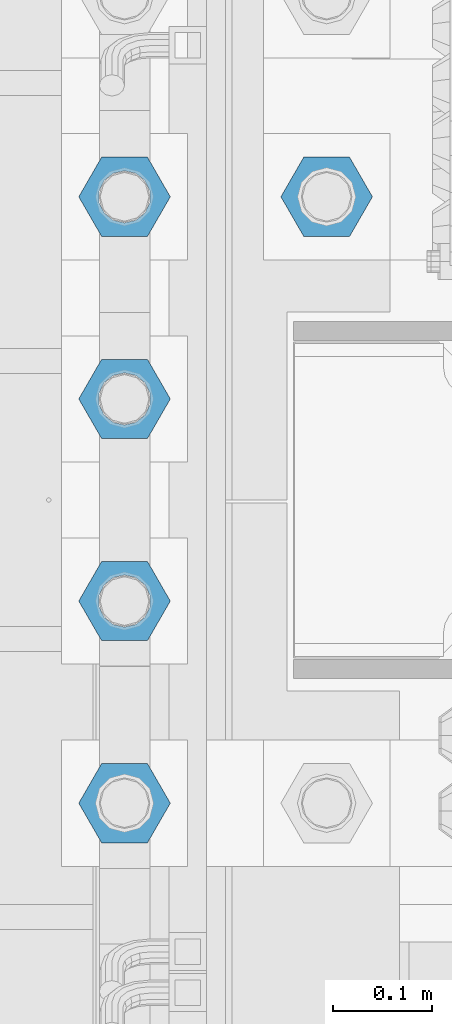
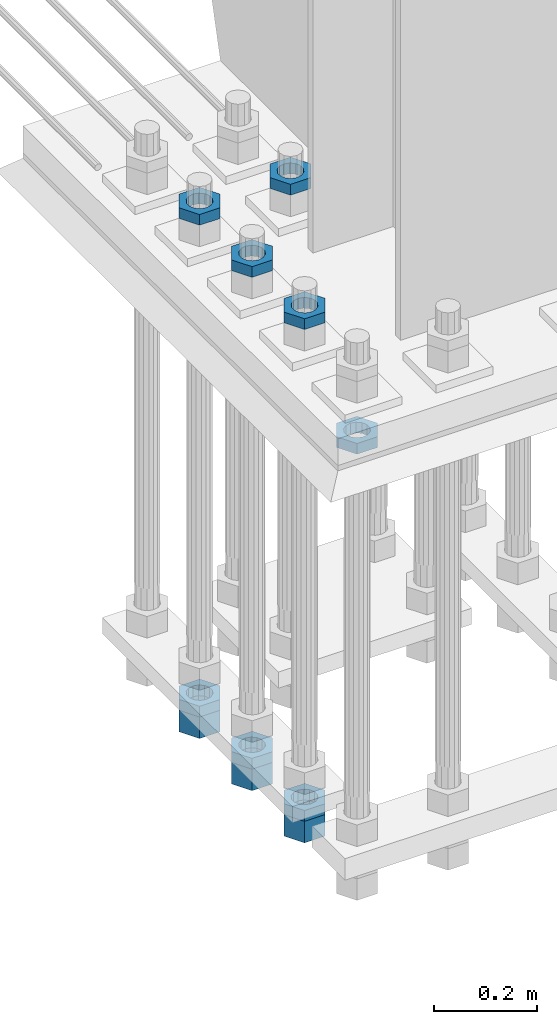
# One storey, part 2091 of 3843: 11 beams, 1 element without a shape of its own.
"""IFC2X3 building model written with IfcOpenShell, lengths in millimetres."""

from ifc_helpers import new_model, si_unit, frame, origin_with_axes, place, context, subcontext, project, spatial, faceted_brep, material, type_object, element, aggregate, save


model = new_model("IFC2X3")

# Units and contexts
model_context = context("Model", 3, precision=1e-05, world=origin_with_axes())
body_context = subcontext(model_context, "Body", "Model", "MODEL_VIEW")
ifc_project = project(units=[si_unit("LENGTHUNIT", "METRE", prefix="MILLI"), si_unit("AREAUNIT", "SQUARE_METRE"), si_unit("VOLUMEUNIT", "CUBIC_METRE"), si_unit("MASSUNIT", "GRAM", prefix="KILO"), si_unit("TIMEUNIT", "SECOND"), si_unit("PLANEANGLEUNIT", "RADIAN"), si_unit("SOLIDANGLEUNIT", "STERADIAN"), si_unit("THERMODYNAMICTEMPERATUREUNIT", "DEGREE_CELSIUS"), si_unit("LUMINOUSINTENSITYUNIT", "LUMEN")], contexts=[model_context])

# Site, building, storey
site_placement = place(None, origin_with_axes())
site = spatial("IfcSite", under=ifc_project, at=site_placement, CompositionType="ELEMENT")
building_placement = place(site_placement, origin_with_axes())
building = spatial("IfcBuilding", under=site, at=building_placement, Name="Undefined", CompositionType="ELEMENT")
storey_placement = place(building_placement, origin_with_axes())
storey = spatial("IfcBuildingStorey", under=building, at=storey_placement, Name="Undefined", CompositionType="ELEMENT", Elevation=0.0)

# Assembly, beams
assembly_placement = place(storey_placement, origin_with_axes())
assembly = element("IfcElementAssembly", 1, at=assembly_placement, inside=storey, Name="TEMPLATE", AssemblyPlace="NOTDEFINED", PredefinedType="RIGID_FRAME")
ifc_material = material(Name="STEEL/A572-50")
beam_type_1 = type_object("IfcBeamType", Name="2_HALF_NUT", PredefinedType="NOTDEFINED")
beam_1_placement = place(assembly_placement, frame((55575.2, 20002.5, 29603.7), z_axis=(0.0, -1.0, 0.0), x_axis=(0.0, 0.0, -1.0)))
beam_1 = element("IfcBeam", 2, at=beam_1_placement, type_object=beam_type_1, material=ifc_material, Name="NUT", ObjectType="2_HALF_NUT", context=body_context, shape_type="Brep", body=[
    faceted_brep([(0.0, -46.0369987487793, 0.0), (0.0, -23.0184993743896, -39.869213104248), (25.4000000000015, -23.0184993743896, -39.869213104248), (25.4000000000015, -46.0369987487793, 0.0), (0.0, 23.0184993743896, -39.869213104248), (25.4000000000015, 23.0184993743896, -39.869213104248), (0.0, 46.0369987487793, 0.0), (25.4000000000015, 46.0369987487793, 0.0), (0.0, 23.0184993743896, 39.869213104248), (25.4000000000015, 23.0184993743896, 39.869213104248), (0.0, -23.0184993743896, 39.869213104248), (25.4000000000015, -23.0184993743896, 39.869213104248), (0.0, 0.0, 26.1940002441406), (0.0, 11.3650617044477, 23.5999013092805), (25.4000000000015, 11.3650617044477, 23.5999013092805), (25.4000000000015, 0.0, 26.1940002441406), (0.0, 20.4791109456419, 16.3316083006721), (25.4000000000015, 20.4791109456419, 16.3316083006721), (0.0, 25.5370200498292, 5.82867859874386), (25.4000000000015, 25.5370200498292, 5.82867859874386), (0.0, 25.5370200498292, -5.82867859874386), (25.4000000000015, 25.5370200498292, -5.82867859874386), (0.0, 20.4791109456419, -16.3316083006721), (25.4000000000015, 20.4791109456419, -16.3316083006721), (0.0, 11.3650617044477, -23.5999013092805), (25.4000000000015, 11.3650617044477, -23.5999013092805), (0.0, 0.0, -26.1940002441406), (25.4000000000015, 0.0, -26.1940002441406), (0.0, -11.3650617044477, -23.5999013092805), (25.4000000000015, -11.3650617044477, -23.5999013092805), (0.0, -20.4791109456419, -16.3316083006721), (25.4000000000015, -20.4791109456419, -16.3316083006721), (0.0, -25.5370200498292, -5.82867859874386), (25.4000000000015, -25.5370200498292, -5.82867859874386), (0.0, -25.5370200498292, 5.82867859874386), (25.4000000000015, -25.5370200498292, 5.82867859874386), (0.0, -20.4791109456419, 16.3316083006721), (25.4000000000015, -20.4791109456419, 16.3316083006721), (0.0, -11.3650617044477, 23.5999013092805), (25.4000000000015, -11.3650617044477, 23.5999013092805)], [[[0, 1, 2, 3]], [[1, 4, 5, 2]], [[4, 6, 7, 5]], [[6, 8, 9, 7]], [[8, 10, 11, 9]], [[10, 0, 3, 11]], [[12, 13, 14, 15]], [[13, 16, 17, 14]], [[16, 18, 19, 17]], [[18, 20, 21, 19]], [[20, 22, 23, 21]], [[22, 24, 25, 23]], [[24, 26, 27, 25]], [[26, 28, 29, 27]], [[28, 30, 31, 29]], [[30, 32, 33, 31]], [[32, 34, 35, 33]], [[34, 36, 37, 35]], [[36, 38, 39, 37]], [[38, 12, 15, 39]], [[5, 7, 9, 11, 3, 2], [17, 19, 21, 23, 25, 27, 29, 31, 33, 35, 37, 39, 15, 14]], [[10, 8, 6, 4, 1, 0], [38, 36, 34, 32, 30, 28, 26, 24, 22, 20, 18, 16, 13, 12]]]),
])
beam_2_placement = place(assembly_placement, frame((55575.2, 20205.7, 29775.15), z_axis=(0.0, -1.0, 0.0), x_axis=(0.0, 0.0, -1.0)))
beam_2 = element("IfcBeam", 3, at=beam_2_placement, type_object=beam_type_1, material=ifc_material, Name="NUT", ObjectType="2_HALF_NUT", context=body_context, shape_type="Brep", body=[
    faceted_brep([(0.0, -46.0369987487793, 0.0), (0.0, -23.0184993743896, -39.869213104248), (25.4000000000015, -23.0184993743896, -39.869213104248), (25.4000000000015, -46.0369987487793, 0.0), (0.0, 23.0184993743896, -39.869213104248), (25.4000000000015, 23.0184993743896, -39.869213104248), (0.0, 46.0369987487793, 0.0), (25.4000000000015, 46.0369987487793, 0.0), (0.0, 23.0184993743896, 39.869213104248), (25.4000000000015, 23.0184993743896, 39.869213104248), (0.0, -23.0184993743896, 39.869213104248), (25.4000000000015, -23.0184993743896, 39.869213104248), (0.0, 0.0, 26.1940002441406), (0.0, 11.3650617044477, 23.5999013092805), (25.4000000000015, 11.3650617044477, 23.5999013092805), (25.4000000000015, 0.0, 26.1940002441406), (0.0, 20.4791109456419, 16.3316083006721), (25.4000000000015, 20.4791109456419, 16.3316083006721), (0.0, 25.5370200498292, 5.82867859874386), (25.4000000000015, 25.5370200498292, 5.82867859874386), (0.0, 25.5370200498292, -5.82867859874386), (25.4000000000015, 25.5370200498292, -5.82867859874386), (0.0, 20.4791109456419, -16.3316083006721), (25.4000000000015, 20.4791109456419, -16.3316083006721), (0.0, 11.3650617044477, -23.5999013092805), (25.4000000000015, 11.3650617044477, -23.5999013092805), (0.0, 0.0, -26.1940002441406), (25.4000000000015, 0.0, -26.1940002441406), (0.0, -11.3650617044477, -23.5999013092805), (25.4000000000015, -11.3650617044477, -23.5999013092805), (0.0, -20.4791109456419, -16.3316083006721), (25.4000000000015, -20.4791109456419, -16.3316083006721), (0.0, -25.5370200498292, -5.82867859874386), (25.4000000000015, -25.5370200498292, -5.82867859874386), (0.0, -25.5370200498292, 5.82867859874386), (25.4000000000015, -25.5370200498292, 5.82867859874386), (0.0, -20.4791109456419, 16.3316083006721), (25.4000000000015, -20.4791109456419, 16.3316083006721), (0.0, -11.3650617044477, 23.5999013092805), (25.4000000000015, -11.3650617044477, 23.5999013092805)], [[[0, 1, 2, 3]], [[1, 4, 5, 2]], [[4, 6, 7, 5]], [[6, 8, 9, 7]], [[8, 10, 11, 9]], [[10, 0, 3, 11]], [[12, 13, 14, 15]], [[13, 16, 17, 14]], [[16, 18, 19, 17]], [[18, 20, 21, 19]], [[20, 22, 23, 21]], [[22, 24, 25, 23]], [[24, 26, 27, 25]], [[26, 28, 29, 27]], [[28, 30, 31, 29]], [[30, 32, 33, 31]], [[32, 34, 35, 33]], [[34, 36, 37, 35]], [[36, 38, 39, 37]], [[38, 12, 15, 39]], [[5, 7, 9, 11, 3, 2], [17, 19, 21, 23, 25, 27, 29, 31, 33, 35, 37, 39, 15, 14]], [[10, 8, 6, 4, 1, 0], [38, 36, 34, 32, 30, 28, 26, 24, 22, 20, 18, 16, 13, 12]]]),
])
beam_3_placement = place(assembly_placement, frame((55575.2, 20205.7, 28613.0999969482), z_axis=(0.0, -1.0, 0.0), x_axis=(0.0, 0.0, -1.0)))
beam_3 = element("IfcBeam", 4, at=beam_3_placement, type_object=beam_type_1, material=ifc_material, Name="NUT", ObjectType="2_HALF_NUT", context=body_context, shape_type="Brep", body=[
    faceted_brep([(0.0, -46.0369987487793, 0.0), (0.0, -23.0184993743896, -39.869213104248), (25.4000000000015, -23.0184993743896, -39.869213104248), (25.4000000000015, -46.0369987487793, 0.0), (0.0, 23.0184993743896, -39.869213104248), (25.4000000000015, 23.0184993743896, -39.869213104248), (0.0, 46.0369987487793, 0.0), (25.4000000000015, 46.0369987487793, 0.0), (0.0, 23.0184993743896, 39.869213104248), (25.4000000000015, 23.0184993743896, 39.869213104248), (0.0, -23.0184993743896, 39.869213104248), (25.4000000000015, -23.0184993743896, 39.869213104248), (0.0, 0.0, 26.1940002441406), (0.0, 11.3650617044477, 23.5999013092805), (25.4000000000015, 11.3650617044477, 23.5999013092805), (25.4000000000015, 0.0, 26.1940002441406), (0.0, 20.4791109456419, 16.3316083006721), (25.4000000000015, 20.4791109456419, 16.3316083006721), (0.0, 25.5370200498292, 5.82867859874386), (25.4000000000015, 25.5370200498292, 5.82867859874386), (0.0, 25.5370200498292, -5.82867859874386), (25.4000000000015, 25.5370200498292, -5.82867859874386), (0.0, 20.4791109456419, -16.3316083006721), (25.4000000000015, 20.4791109456419, -16.3316083006721), (0.0, 11.3650617044477, -23.5999013092805), (25.4000000000015, 11.3650617044477, -23.5999013092805), (0.0, 0.0, -26.1940002441406), (25.4000000000015, 0.0, -26.1940002441406), (0.0, -11.3650617044477, -23.5999013092805), (25.4000000000015, -11.3650617044477, -23.5999013092805), (0.0, -20.4791109456419, -16.3316083006721), (25.4000000000015, -20.4791109456419, -16.3316083006721), (0.0, -25.5370200498292, -5.82867859874386), (25.4000000000015, -25.5370200498292, -5.82867859874386), (0.0, -25.5370200498292, 5.82867859874386), (25.4000000000015, -25.5370200498292, 5.82867859874386), (0.0, -20.4791109456419, 16.3316083006721), (25.4000000000015, -20.4791109456419, 16.3316083006721), (0.0, -11.3650617044477, 23.5999013092805), (25.4000000000015, -11.3650617044477, 23.5999013092805)], [[[0, 1, 2, 3]], [[1, 4, 5, 2]], [[4, 6, 7, 5]], [[6, 8, 9, 7]], [[8, 10, 11, 9]], [[10, 0, 3, 11]], [[12, 13, 14, 15]], [[13, 16, 17, 14]], [[16, 18, 19, 17]], [[18, 20, 21, 19]], [[20, 22, 23, 21]], [[22, 24, 25, 23]], [[24, 26, 27, 25]], [[26, 28, 29, 27]], [[28, 30, 31, 29]], [[30, 32, 33, 31]], [[32, 34, 35, 33]], [[34, 36, 37, 35]], [[36, 38, 39, 37]], [[38, 12, 15, 39]], [[5, 7, 9, 11, 3, 2], [17, 19, 21, 23, 25, 27, 29, 31, 33, 35, 37, 39, 15, 14]], [[10, 8, 6, 4, 1, 0], [38, 36, 34, 32, 30, 28, 26, 24, 22, 20, 18, 16, 13, 12]]]),
])
beam_4_placement = place(assembly_placement, frame((55575.2, 20408.9, 29775.15), z_axis=(0.0, -1.0, 0.0), x_axis=(0.0, 0.0, -1.0)))
beam_4 = element("IfcBeam", 5, at=beam_4_placement, type_object=beam_type_1, material=ifc_material, Name="NUT", ObjectType="2_HALF_NUT", context=body_context, shape_type="Brep", body=[
    faceted_brep([(0.0, -46.0369987487793, 0.0), (0.0, -23.0184993743896, -39.869213104248), (25.4000000000015, -23.0184993743896, -39.869213104248), (25.4000000000015, -46.0369987487793, 0.0), (0.0, 23.0184993743896, -39.869213104248), (25.4000000000015, 23.0184993743896, -39.869213104248), (0.0, 46.0369987487793, 0.0), (25.4000000000015, 46.0369987487793, 0.0), (0.0, 23.0184993743896, 39.869213104248), (25.4000000000015, 23.0184993743896, 39.869213104248), (0.0, -23.0184993743896, 39.869213104248), (25.4000000000015, -23.0184993743896, 39.869213104248), (0.0, 0.0, 26.1940002441406), (0.0, 11.3650617044477, 23.5999013092805), (25.4000000000015, 11.3650617044477, 23.5999013092805), (25.4000000000015, 0.0, 26.1940002441406), (0.0, 20.4791109456419, 16.3316083006721), (25.4000000000015, 20.4791109456419, 16.3316083006721), (0.0, 25.5370200498292, 5.82867859874386), (25.4000000000015, 25.5370200498292, 5.82867859874386), (0.0, 25.5370200498292, -5.82867859874386), (25.4000000000015, 25.5370200498292, -5.82867859874386), (0.0, 20.4791109456419, -16.3316083006721), (25.4000000000015, 20.4791109456419, -16.3316083006721), (0.0, 11.3650617044477, -23.5999013092805), (25.4000000000015, 11.3650617044477, -23.5999013092805), (0.0, 0.0, -26.1940002441406), (25.4000000000015, 0.0, -26.1940002441406), (0.0, -11.3650617044477, -23.5999013092805), (25.4000000000015, -11.3650617044477, -23.5999013092805), (0.0, -20.4791109456419, -16.3316083006721), (25.4000000000015, -20.4791109456419, -16.3316083006721), (0.0, -25.5370200498292, -5.82867859874386), (25.4000000000015, -25.5370200498292, -5.82867859874386), (0.0, -25.5370200498292, 5.82867859874386), (25.4000000000015, -25.5370200498292, 5.82867859874386), (0.0, -20.4791109456419, 16.3316083006721), (25.4000000000015, -20.4791109456419, 16.3316083006721), (0.0, -11.3650617044477, 23.5999013092805), (25.4000000000015, -11.3650617044477, 23.5999013092805)], [[[0, 1, 2, 3]], [[1, 4, 5, 2]], [[4, 6, 7, 5]], [[6, 8, 9, 7]], [[8, 10, 11, 9]], [[10, 0, 3, 11]], [[12, 13, 14, 15]], [[13, 16, 17, 14]], [[16, 18, 19, 17]], [[18, 20, 21, 19]], [[20, 22, 23, 21]], [[22, 24, 25, 23]], [[24, 26, 27, 25]], [[26, 28, 29, 27]], [[28, 30, 31, 29]], [[30, 32, 33, 31]], [[32, 34, 35, 33]], [[34, 36, 37, 35]], [[36, 38, 39, 37]], [[38, 12, 15, 39]], [[5, 7, 9, 11, 3, 2], [17, 19, 21, 23, 25, 27, 29, 31, 33, 35, 37, 39, 15, 14]], [[10, 8, 6, 4, 1, 0], [38, 36, 34, 32, 30, 28, 26, 24, 22, 20, 18, 16, 13, 12]]]),
])
beam_5_placement = place(assembly_placement, frame((55575.2, 20408.9, 28613.0999969482), z_axis=(0.0, -1.0, 0.0), x_axis=(0.0, 0.0, -1.0)))
beam_5 = element("IfcBeam", 6, at=beam_5_placement, type_object=beam_type_1, material=ifc_material, Name="NUT", ObjectType="2_HALF_NUT", context=body_context, shape_type="Brep", body=[
    faceted_brep([(0.0, -46.0369987487793, 0.0), (0.0, -23.0184993743896, -39.869213104248), (25.4000000000015, -23.0184993743896, -39.869213104248), (25.4000000000015, -46.0369987487793, 0.0), (0.0, 23.0184993743896, -39.869213104248), (25.4000000000015, 23.0184993743896, -39.869213104248), (0.0, 46.0369987487793, 0.0), (25.4000000000015, 46.0369987487793, 0.0), (0.0, 23.0184993743896, 39.869213104248), (25.4000000000015, 23.0184993743896, 39.869213104248), (0.0, -23.0184993743896, 39.869213104248), (25.4000000000015, -23.0184993743896, 39.869213104248), (0.0, 0.0, 26.1940002441406), (0.0, 11.3650617044477, 23.5999013092805), (25.4000000000015, 11.3650617044477, 23.5999013092805), (25.4000000000015, 0.0, 26.1940002441406), (0.0, 20.4791109456419, 16.3316083006721), (25.4000000000015, 20.4791109456419, 16.3316083006721), (0.0, 25.5370200498292, 5.82867859874386), (25.4000000000015, 25.5370200498292, 5.82867859874386), (0.0, 25.5370200498292, -5.82867859874386), (25.4000000000015, 25.5370200498292, -5.82867859874386), (0.0, 20.4791109456419, -16.3316083006721), (25.4000000000015, 20.4791109456419, -16.3316083006721), (0.0, 11.3650617044477, -23.5999013092805), (25.4000000000015, 11.3650617044477, -23.5999013092805), (0.0, 0.0, -26.1940002441406), (25.4000000000015, 0.0, -26.1940002441406), (0.0, -11.3650617044477, -23.5999013092805), (25.4000000000015, -11.3650617044477, -23.5999013092805), (0.0, -20.4791109456419, -16.3316083006721), (25.4000000000015, -20.4791109456419, -16.3316083006721), (0.0, -25.5370200498292, -5.82867859874386), (25.4000000000015, -25.5370200498292, -5.82867859874386), (0.0, -25.5370200498292, 5.82867859874386), (25.4000000000015, -25.5370200498292, 5.82867859874386), (0.0, -20.4791109456419, 16.3316083006721), (25.4000000000015, -20.4791109456419, 16.3316083006721), (0.0, -11.3650617044477, 23.5999013092805), (25.4000000000015, -11.3650617044477, 23.5999013092805)], [[[0, 1, 2, 3]], [[1, 4, 5, 2]], [[4, 6, 7, 5]], [[6, 8, 9, 7]], [[8, 10, 11, 9]], [[10, 0, 3, 11]], [[12, 13, 14, 15]], [[13, 16, 17, 14]], [[16, 18, 19, 17]], [[18, 20, 21, 19]], [[20, 22, 23, 21]], [[22, 24, 25, 23]], [[24, 26, 27, 25]], [[26, 28, 29, 27]], [[28, 30, 31, 29]], [[30, 32, 33, 31]], [[32, 34, 35, 33]], [[34, 36, 37, 35]], [[36, 38, 39, 37]], [[38, 12, 15, 39]], [[5, 7, 9, 11, 3, 2], [17, 19, 21, 23, 25, 27, 29, 31, 33, 35, 37, 39, 15, 14]], [[10, 8, 6, 4, 1, 0], [38, 36, 34, 32, 30, 28, 26, 24, 22, 20, 18, 16, 13, 12]]]),
])
beam_6_placement = place(assembly_placement, frame((55575.2, 20612.1, 29775.15), z_axis=(0.0, -1.0, 0.0), x_axis=(0.0, 0.0, -1.0)))
beam_6 = element("IfcBeam", 7, at=beam_6_placement, type_object=beam_type_1, material=ifc_material, Name="NUT", ObjectType="2_HALF_NUT", context=body_context, shape_type="Brep", body=[
    faceted_brep([(0.0, -46.0369987487793, 0.0), (0.0, -23.0184993743896, -39.869213104248), (25.4000000000015, -23.0184993743896, -39.869213104248), (25.4000000000015, -46.0369987487793, 0.0), (0.0, 23.0184993743896, -39.869213104248), (25.4000000000015, 23.0184993743896, -39.869213104248), (0.0, 46.0369987487793, 0.0), (25.4000000000015, 46.0369987487793, 0.0), (0.0, 23.0184993743896, 39.869213104248), (25.4000000000015, 23.0184993743896, 39.869213104248), (0.0, -23.0184993743896, 39.869213104248), (25.4000000000015, -23.0184993743896, 39.869213104248), (0.0, 0.0, 26.1940002441406), (0.0, 11.3650617044477, 23.5999013092805), (25.4000000000015, 11.3650617044477, 23.5999013092805), (25.4000000000015, 0.0, 26.1940002441406), (0.0, 20.4791109456419, 16.3316083006721), (25.4000000000015, 20.4791109456419, 16.3316083006721), (0.0, 25.5370200498292, 5.82867859874386), (25.4000000000015, 25.5370200498292, 5.82867859874386), (0.0, 25.5370200498292, -5.82867859874386), (25.4000000000015, 25.5370200498292, -5.82867859874386), (0.0, 20.4791109456419, -16.3316083006721), (25.4000000000015, 20.4791109456419, -16.3316083006721), (0.0, 11.3650617044477, -23.5999013092805), (25.4000000000015, 11.3650617044477, -23.5999013092805), (0.0, 0.0, -26.1940002441406), (25.4000000000015, 0.0, -26.1940002441406), (0.0, -11.3650617044477, -23.5999013092805), (25.4000000000015, -11.3650617044477, -23.5999013092805), (0.0, -20.4791109456419, -16.3316083006721), (25.4000000000015, -20.4791109456419, -16.3316083006721), (0.0, -25.5370200498292, -5.82867859874386), (25.4000000000015, -25.5370200498292, -5.82867859874386), (0.0, -25.5370200498292, 5.82867859874386), (25.4000000000015, -25.5370200498292, 5.82867859874386), (0.0, -20.4791109456419, 16.3316083006721), (25.4000000000015, -20.4791109456419, 16.3316083006721), (0.0, -11.3650617044477, 23.5999013092805), (25.4000000000015, -11.3650617044477, 23.5999013092805)], [[[0, 1, 2, 3]], [[1, 4, 5, 2]], [[4, 6, 7, 5]], [[6, 8, 9, 7]], [[8, 10, 11, 9]], [[10, 0, 3, 11]], [[12, 13, 14, 15]], [[13, 16, 17, 14]], [[16, 18, 19, 17]], [[18, 20, 21, 19]], [[20, 22, 23, 21]], [[22, 24, 25, 23]], [[24, 26, 27, 25]], [[26, 28, 29, 27]], [[28, 30, 31, 29]], [[30, 32, 33, 31]], [[32, 34, 35, 33]], [[34, 36, 37, 35]], [[36, 38, 39, 37]], [[38, 12, 15, 39]], [[5, 7, 9, 11, 3, 2], [17, 19, 21, 23, 25, 27, 29, 31, 33, 35, 37, 39, 15, 14]], [[10, 8, 6, 4, 1, 0], [38, 36, 34, 32, 30, 28, 26, 24, 22, 20, 18, 16, 13, 12]]]),
])
beam_7_placement = place(assembly_placement, frame((55575.2, 20612.1, 28613.0999969482), z_axis=(0.0, -1.0, 0.0), x_axis=(0.0, 0.0, -1.0)))
beam_7 = element("IfcBeam", 8, at=beam_7_placement, type_object=beam_type_1, material=ifc_material, Name="NUT", ObjectType="2_HALF_NUT", context=body_context, shape_type="Brep", body=[
    faceted_brep([(0.0, -46.0369987487793, 0.0), (0.0, -23.0184993743896, -39.869213104248), (25.4000000000015, -23.0184993743896, -39.869213104248), (25.4000000000015, -46.0369987487793, 0.0), (0.0, 23.0184993743896, -39.869213104248), (25.4000000000015, 23.0184993743896, -39.869213104248), (0.0, 46.0369987487793, 0.0), (25.4000000000015, 46.0369987487793, 0.0), (0.0, 23.0184993743896, 39.869213104248), (25.4000000000015, 23.0184993743896, 39.869213104248), (0.0, -23.0184993743896, 39.869213104248), (25.4000000000015, -23.0184993743896, 39.869213104248), (0.0, 0.0, 26.1940002441406), (0.0, 11.3650617044477, 23.5999013092805), (25.4000000000015, 11.3650617044477, 23.5999013092805), (25.4000000000015, 0.0, 26.1940002441406), (0.0, 20.4791109456419, 16.3316083006721), (25.4000000000015, 20.4791109456419, 16.3316083006721), (0.0, 25.5370200498292, 5.82867859874386), (25.4000000000015, 25.5370200498292, 5.82867859874386), (0.0, 25.5370200498292, -5.82867859874386), (25.4000000000015, 25.5370200498292, -5.82867859874386), (0.0, 20.4791109456419, -16.3316083006721), (25.4000000000015, 20.4791109456419, -16.3316083006721), (0.0, 11.3650617044477, -23.5999013092805), (25.4000000000015, 11.3650617044477, -23.5999013092805), (0.0, 0.0, -26.1940002441406), (25.4000000000015, 0.0, -26.1940002441406), (0.0, -11.3650617044477, -23.5999013092805), (25.4000000000015, -11.3650617044477, -23.5999013092805), (0.0, -20.4791109456419, -16.3316083006721), (25.4000000000015, -20.4791109456419, -16.3316083006721), (0.0, -25.5370200498292, -5.82867859874386), (25.4000000000015, -25.5370200498292, -5.82867859874386), (0.0, -25.5370200498292, 5.82867859874386), (25.4000000000015, -25.5370200498292, 5.82867859874386), (0.0, -20.4791109456419, 16.3316083006721), (25.4000000000015, -20.4791109456419, 16.3316083006721), (0.0, -11.3650617044477, 23.5999013092805), (25.4000000000015, -11.3650617044477, 23.5999013092805)], [[[0, 1, 2, 3]], [[1, 4, 5, 2]], [[4, 6, 7, 5]], [[6, 8, 9, 7]], [[8, 10, 11, 9]], [[10, 0, 3, 11]], [[12, 13, 14, 15]], [[13, 16, 17, 14]], [[16, 18, 19, 17]], [[18, 20, 21, 19]], [[20, 22, 23, 21]], [[22, 24, 25, 23]], [[24, 26, 27, 25]], [[26, 28, 29, 27]], [[28, 30, 31, 29]], [[30, 32, 33, 31]], [[32, 34, 35, 33]], [[34, 36, 37, 35]], [[36, 38, 39, 37]], [[38, 12, 15, 39]], [[5, 7, 9, 11, 3, 2], [17, 19, 21, 23, 25, 27, 29, 31, 33, 35, 37, 39, 15, 14]], [[10, 8, 6, 4, 1, 0], [38, 36, 34, 32, 30, 28, 26, 24, 22, 20, 18, 16, 13, 12]]]),
])
beam_8_placement = place(assembly_placement, frame((55778.4, 20612.1, 29775.15), z_axis=(0.0, -1.0, 0.0), x_axis=(0.0, 0.0, -1.0)))
beam_8 = element("IfcBeam", 9, at=beam_8_placement, type_object=beam_type_1, material=ifc_material, Name="NUT", ObjectType="2_HALF_NUT", context=body_context, shape_type="Brep", body=[
    faceted_brep([(0.0, -46.0369987487793, 0.0), (0.0, -23.0184993743896, -39.869213104248), (25.4000000000015, -23.0184993743896, -39.869213104248), (25.4000000000015, -46.0369987487793, 0.0), (0.0, 23.0184993743896, -39.869213104248), (25.4000000000015, 23.0184993743896, -39.869213104248), (0.0, 46.0369987487793, 0.0), (25.4000000000015, 46.0369987487793, 0.0), (0.0, 23.0184993743896, 39.869213104248), (25.4000000000015, 23.0184993743896, 39.869213104248), (0.0, -23.0184993743896, 39.869213104248), (25.4000000000015, -23.0184993743896, 39.869213104248), (0.0, 0.0, 26.1940002441406), (0.0, 11.3650617044477, 23.5999013092805), (25.4000000000015, 11.3650617044477, 23.5999013092805), (25.4000000000015, 0.0, 26.1940002441406), (0.0, 20.4791109456419, 16.3316083006721), (25.4000000000015, 20.4791109456419, 16.3316083006721), (0.0, 25.5370200498292, 5.82867859874386), (25.4000000000015, 25.5370200498292, 5.82867859874386), (0.0, 25.5370200498292, -5.82867859874386), (25.4000000000015, 25.5370200498292, -5.82867859874386), (0.0, 20.4791109456419, -16.3316083006721), (25.4000000000015, 20.4791109456419, -16.3316083006721), (0.0, 11.3650617044477, -23.5999013092805), (25.4000000000015, 11.3650617044477, -23.5999013092805), (0.0, 0.0, -26.1940002441406), (25.4000000000015, 0.0, -26.1940002441406), (0.0, -11.3650617044477, -23.5999013092805), (25.4000000000015, -11.3650617044477, -23.5999013092805), (0.0, -20.4791109456419, -16.3316083006721), (25.4000000000015, -20.4791109456419, -16.3316083006721), (0.0, -25.5370200498292, -5.82867859874386), (25.4000000000015, -25.5370200498292, -5.82867859874386), (0.0, -25.5370200498292, 5.82867859874386), (25.4000000000015, -25.5370200498292, 5.82867859874386), (0.0, -20.4791109456419, 16.3316083006721), (25.4000000000015, -20.4791109456419, 16.3316083006721), (0.0, -11.3650617044477, 23.5999013092805), (25.4000000000015, -11.3650617044477, 23.5999013092805)], [[[0, 1, 2, 3]], [[1, 4, 5, 2]], [[4, 6, 7, 5]], [[6, 8, 9, 7]], [[8, 10, 11, 9]], [[10, 0, 3, 11]], [[12, 13, 14, 15]], [[13, 16, 17, 14]], [[16, 18, 19, 17]], [[18, 20, 21, 19]], [[20, 22, 23, 21]], [[22, 24, 25, 23]], [[24, 26, 27, 25]], [[26, 28, 29, 27]], [[28, 30, 31, 29]], [[30, 32, 33, 31]], [[32, 34, 35, 33]], [[34, 36, 37, 35]], [[36, 38, 39, 37]], [[38, 12, 15, 39]], [[5, 7, 9, 11, 3, 2], [17, 19, 21, 23, 25, 27, 29, 31, 33, 35, 37, 39, 15, 14]], [[10, 8, 6, 4, 1, 0], [38, 36, 34, 32, 30, 28, 26, 24, 22, 20, 18, 16, 13, 12]]]),
])
beam_type_2 = type_object("IfcBeamType", Name="2_HEAVY_HEX_NUT", PredefinedType="NOTDEFINED")
beam_9_placement = place(assembly_placement, frame((55575.2, 20205.7, 28587.6999969482), z_axis=(0.0, -1.0, 0.0), x_axis=(0.0, 0.0, -1.0)))
beam_9 = element("IfcBeam", 10, at=beam_9_placement, type_object=beam_type_2, material=ifc_material, Name="NUT", ObjectType="2_HEAVY_HEX_NUT", context=body_context, shape_type="Brep", body=[
    faceted_brep([(0.0, -46.0369987487793, 0.0), (0.0, -23.0184993743896, -39.869213104248), (50.7999999999993, -23.0184993743896, -39.869213104248), (50.7999999999993, -46.0369987487793, 0.0), (0.0, 23.0184993743896, -39.869213104248), (50.7999999999993, 23.0184993743896, -39.869213104248), (0.0, 46.0369987487793, 0.0), (50.7999999999993, 46.0369987487793, 0.0), (0.0, 23.0184993743896, 39.869213104248), (50.7999999999993, 23.0184993743896, 39.869213104248), (0.0, -23.0184993743896, 39.869213104248), (50.7999999999993, -23.0184993743896, 39.869213104248), (0.0, 0.0, 26.1940002441406), (0.0, 11.3650617044477, 23.5999013092805), (50.7999999999993, 11.3650617044477, 23.5999013092805), (50.7999999999993, 0.0, 26.1940002441406), (0.0, 20.4791109456419, 16.3316083006721), (50.7999999999993, 20.4791109456419, 16.3316083006721), (0.0, 25.5370200498292, 5.82867859874386), (50.7999999999993, 25.5370200498292, 5.82867859874386), (0.0, 25.5370200498292, -5.82867859874386), (50.7999999999993, 25.5370200498292, -5.82867859874386), (0.0, 20.4791109456419, -16.3316083006721), (50.7999999999993, 20.4791109456419, -16.3316083006721), (0.0, 11.3650617044477, -23.5999013092805), (50.7999999999993, 11.3650617044477, -23.5999013092805), (0.0, 0.0, -26.1940002441406), (50.7999999999993, 0.0, -26.1940002441406), (0.0, -11.3650617044477, -23.5999013092805), (50.7999999999993, -11.3650617044477, -23.5999013092805), (0.0, -20.4791109456419, -16.3316083006721), (50.7999999999993, -20.4791109456419, -16.3316083006721), (0.0, -25.5370200498292, -5.82867859874386), (50.7999999999993, -25.5370200498292, -5.82867859874386), (0.0, -25.5370200498292, 5.82867859874386), (50.7999999999993, -25.5370200498292, 5.82867859874386), (0.0, -20.4791109456419, 16.3316083006721), (50.7999999999993, -20.4791109456419, 16.3316083006721), (0.0, -11.3650617044477, 23.5999013092805), (50.7999999999993, -11.3650617044477, 23.5999013092805)], [[[0, 1, 2, 3]], [[1, 4, 5, 2]], [[4, 6, 7, 5]], [[6, 8, 9, 7]], [[8, 10, 11, 9]], [[10, 0, 3, 11]], [[12, 13, 14, 15]], [[13, 16, 17, 14]], [[16, 18, 19, 17]], [[18, 20, 21, 19]], [[20, 22, 23, 21]], [[22, 24, 25, 23]], [[24, 26, 27, 25]], [[26, 28, 29, 27]], [[28, 30, 31, 29]], [[30, 32, 33, 31]], [[32, 34, 35, 33]], [[34, 36, 37, 35]], [[36, 38, 39, 37]], [[38, 12, 15, 39]], [[5, 7, 9, 11, 3, 2], [17, 19, 21, 23, 25, 27, 29, 31, 33, 35, 37, 39, 15, 14]], [[10, 8, 6, 4, 1, 0], [38, 36, 34, 32, 30, 28, 26, 24, 22, 20, 18, 16, 13, 12]]]),
])
beam_10_placement = place(assembly_placement, frame((55575.2, 20408.9, 28587.6999969482), z_axis=(0.0, -1.0, 0.0), x_axis=(0.0, 0.0, -1.0)))
beam_10 = element("IfcBeam", 11, at=beam_10_placement, type_object=beam_type_2, material=ifc_material, Name="NUT", ObjectType="2_HEAVY_HEX_NUT", context=body_context, shape_type="Brep", body=[
    faceted_brep([(0.0, -46.0369987487793, 0.0), (0.0, -23.0184993743896, -39.869213104248), (50.7999999999993, -23.0184993743896, -39.869213104248), (50.7999999999993, -46.0369987487793, 0.0), (0.0, 23.0184993743896, -39.869213104248), (50.7999999999993, 23.0184993743896, -39.869213104248), (0.0, 46.0369987487793, 0.0), (50.7999999999993, 46.0369987487793, 0.0), (0.0, 23.0184993743896, 39.869213104248), (50.7999999999993, 23.0184993743896, 39.869213104248), (0.0, -23.0184993743896, 39.869213104248), (50.7999999999993, -23.0184993743896, 39.869213104248), (0.0, 0.0, 26.1940002441406), (0.0, 11.3650617044477, 23.5999013092805), (50.7999999999993, 11.3650617044477, 23.5999013092805), (50.7999999999993, 0.0, 26.1940002441406), (0.0, 20.4791109456419, 16.3316083006721), (50.7999999999993, 20.4791109456419, 16.3316083006721), (0.0, 25.5370200498292, 5.82867859874386), (50.7999999999993, 25.5370200498292, 5.82867859874386), (0.0, 25.5370200498292, -5.82867859874386), (50.7999999999993, 25.5370200498292, -5.82867859874386), (0.0, 20.4791109456419, -16.3316083006721), (50.7999999999993, 20.4791109456419, -16.3316083006721), (0.0, 11.3650617044477, -23.5999013092805), (50.7999999999993, 11.3650617044477, -23.5999013092805), (0.0, 0.0, -26.1940002441406), (50.7999999999993, 0.0, -26.1940002441406), (0.0, -11.3650617044477, -23.5999013092805), (50.7999999999993, -11.3650617044477, -23.5999013092805), (0.0, -20.4791109456419, -16.3316083006721), (50.7999999999993, -20.4791109456419, -16.3316083006721), (0.0, -25.5370200498292, -5.82867859874386), (50.7999999999993, -25.5370200498292, -5.82867859874386), (0.0, -25.5370200498292, 5.82867859874386), (50.7999999999993, -25.5370200498292, 5.82867859874386), (0.0, -20.4791109456419, 16.3316083006721), (50.7999999999993, -20.4791109456419, 16.3316083006721), (0.0, -11.3650617044477, 23.5999013092805), (50.7999999999993, -11.3650617044477, 23.5999013092805)], [[[0, 1, 2, 3]], [[1, 4, 5, 2]], [[4, 6, 7, 5]], [[6, 8, 9, 7]], [[8, 10, 11, 9]], [[10, 0, 3, 11]], [[12, 13, 14, 15]], [[13, 16, 17, 14]], [[16, 18, 19, 17]], [[18, 20, 21, 19]], [[20, 22, 23, 21]], [[22, 24, 25, 23]], [[24, 26, 27, 25]], [[26, 28, 29, 27]], [[28, 30, 31, 29]], [[30, 32, 33, 31]], [[32, 34, 35, 33]], [[34, 36, 37, 35]], [[36, 38, 39, 37]], [[38, 12, 15, 39]], [[5, 7, 9, 11, 3, 2], [17, 19, 21, 23, 25, 27, 29, 31, 33, 35, 37, 39, 15, 14]], [[10, 8, 6, 4, 1, 0], [38, 36, 34, 32, 30, 28, 26, 24, 22, 20, 18, 16, 13, 12]]]),
])
beam_11_placement = place(assembly_placement, frame((55575.2, 20612.1, 28587.6999969482), z_axis=(0.0, -1.0, 0.0), x_axis=(0.0, 0.0, -1.0)))
beam_11 = element("IfcBeam", 12, at=beam_11_placement, type_object=beam_type_2, material=ifc_material, Name="NUT", ObjectType="2_HEAVY_HEX_NUT", context=body_context, shape_type="Brep", body=[
    faceted_brep([(0.0, -46.0369987487793, 0.0), (0.0, -23.0184993743896, -39.869213104248), (50.7999999999993, -23.0184993743896, -39.869213104248), (50.7999999999993, -46.0369987487793, 0.0), (0.0, 23.0184993743896, -39.869213104248), (50.7999999999993, 23.0184993743896, -39.869213104248), (0.0, 46.0369987487793, 0.0), (50.7999999999993, 46.0369987487793, 0.0), (0.0, 23.0184993743896, 39.869213104248), (50.7999999999993, 23.0184993743896, 39.869213104248), (0.0, -23.0184993743896, 39.869213104248), (50.7999999999993, -23.0184993743896, 39.869213104248), (0.0, 0.0, 26.1940002441406), (0.0, 11.3650617044477, 23.5999013092805), (50.7999999999993, 11.3650617044477, 23.5999013092805), (50.7999999999993, 0.0, 26.1940002441406), (0.0, 20.4791109456419, 16.3316083006721), (50.7999999999993, 20.4791109456419, 16.3316083006721), (0.0, 25.5370200498292, 5.82867859874386), (50.7999999999993, 25.5370200498292, 5.82867859874386), (0.0, 25.5370200498292, -5.82867859874386), (50.7999999999993, 25.5370200498292, -5.82867859874386), (0.0, 20.4791109456419, -16.3316083006721), (50.7999999999993, 20.4791109456419, -16.3316083006721), (0.0, 11.3650617044477, -23.5999013092805), (50.7999999999993, 11.3650617044477, -23.5999013092805), (0.0, 0.0, -26.1940002441406), (50.7999999999993, 0.0, -26.1940002441406), (0.0, -11.3650617044477, -23.5999013092805), (50.7999999999993, -11.3650617044477, -23.5999013092805), (0.0, -20.4791109456419, -16.3316083006721), (50.7999999999993, -20.4791109456419, -16.3316083006721), (0.0, -25.5370200498292, -5.82867859874386), (50.7999999999993, -25.5370200498292, -5.82867859874386), (0.0, -25.5370200498292, 5.82867859874386), (50.7999999999993, -25.5370200498292, 5.82867859874386), (0.0, -20.4791109456419, 16.3316083006721), (50.7999999999993, -20.4791109456419, 16.3316083006721), (0.0, -11.3650617044477, 23.5999013092805), (50.7999999999993, -11.3650617044477, 23.5999013092805)], [[[0, 1, 2, 3]], [[1, 4, 5, 2]], [[4, 6, 7, 5]], [[6, 8, 9, 7]], [[8, 10, 11, 9]], [[10, 0, 3, 11]], [[12, 13, 14, 15]], [[13, 16, 17, 14]], [[16, 18, 19, 17]], [[18, 20, 21, 19]], [[20, 22, 23, 21]], [[22, 24, 25, 23]], [[24, 26, 27, 25]], [[26, 28, 29, 27]], [[28, 30, 31, 29]], [[30, 32, 33, 31]], [[32, 34, 35, 33]], [[34, 36, 37, 35]], [[36, 38, 39, 37]], [[38, 12, 15, 39]], [[5, 7, 9, 11, 3, 2], [17, 19, 21, 23, 25, 27, 29, 31, 33, 35, 37, 39, 15, 14]], [[10, 8, 6, 4, 1, 0], [38, 36, 34, 32, 30, 28, 26, 24, 22, 20, 18, 16, 13, 12]]]),
])
aggregate(assembly, [beam_1, beam_2, beam_9, beam_3, beam_4, beam_10, beam_5, beam_6, beam_11, beam_7, beam_8])

save(model, "model.ifc")
